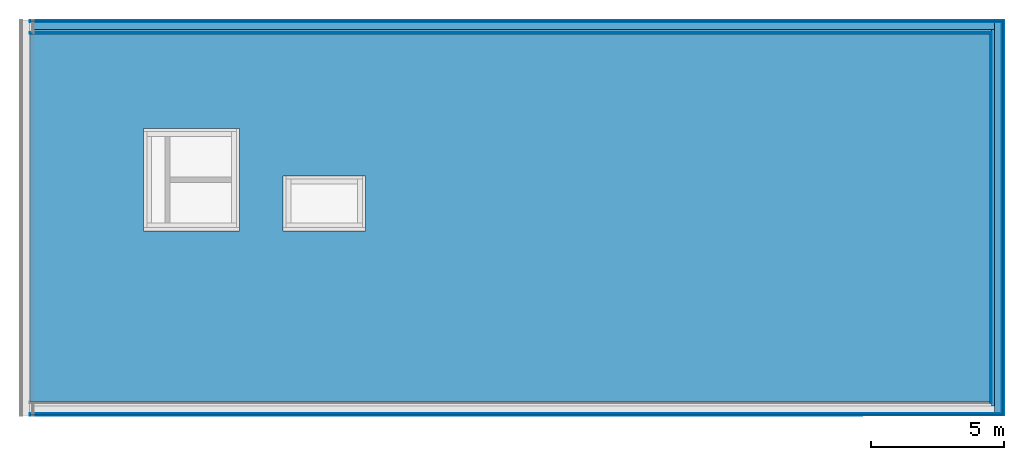
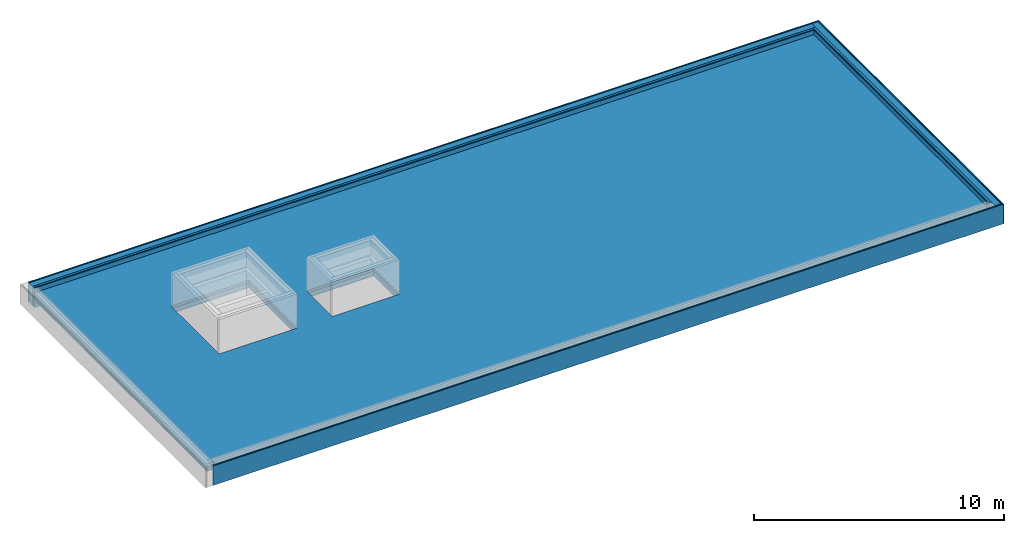
# One storey, part 2 of 3: 23 building element parts, 4 elements without a shape of their own.
"""IFC4 building model written with IfcOpenShell, lengths in metres."""

from ifc_helpers import new_model, entity, si_unit, converted_unit, derived_unit, direction, frame, origin_with_axes, place, context, subcontext, project, spatial, polygons, material, type_object, element, aggregate, save


model = new_model("IFC4")

# Units and contexts
model_context = context("Model", 3, precision=1e-05, world=origin_with_axes(), true_north=direction((0.0, 1.0)))
body_context = subcontext(model_context, "Body", "Model", "MODEL_VIEW")
ifc_project = project(units=[si_unit("LENGTHUNIT", "METRE"), si_unit("AREAUNIT", "SQUARE_METRE"), si_unit("VOLUMEUNIT", "CUBIC_METRE"), converted_unit("PLANEANGLEUNIT", "DEGREE", entity("IfcPlaneAngleMeasure", 0.0174532925199433), si_unit("PLANEANGLEUNIT", "RADIAN"), dimensions=[0, 0, 0, 0, 0, 0, 0]), converted_unit("TIMEUNIT", "Year", entity("IfcTimeMeasure", 31557600.0), si_unit("TIMEUNIT", "SECOND"), dimensions=[0, 0, 1, 0, 0, 0, 0]), si_unit("MASSUNIT", "GRAM", prefix="KILO"), si_unit("THERMODYNAMICTEMPERATUREUNIT", "DEGREE_CELSIUS"), si_unit("LUMINOUSINTENSITYUNIT", "LUMEN"), si_unit("ENERGYUNIT", "JOULE", prefix="MEGA"), derived_unit("THERMALCONDUCTANCEUNIT", [(si_unit("POWERUNIT", "WATT"), 1), (si_unit("LENGTHUNIT", "METRE"), -1), (si_unit("THERMODYNAMICTEMPERATUREUNIT", "KELVIN"), -1)]), derived_unit("SPECIFICHEATCAPACITYUNIT", [(si_unit("ENERGYUNIT", "JOULE"), 1), (si_unit("MASSUNIT", "GRAM", prefix="KILO"), -1), (si_unit("THERMODYNAMICTEMPERATUREUNIT", "KELVIN"), -1)]), derived_unit("MASSDENSITYUNIT", [(si_unit("MASSUNIT", "GRAM", prefix="KILO"), 1), (si_unit("VOLUMEUNIT", "CUBIC_METRE"), -1)])], contexts=[model_context])

# Site, building, storey
site_placement = place(None, origin_with_axes())
site = spatial("IfcSite", under=ifc_project, at=site_placement, CompositionType="ELEMENT")
building_placement = place(site_placement, origin_with_axes())
building = spatial("IfcBuilding", under=site, at=building_placement, CompositionType="ELEMENT")
storey_placement = place(building_placement, frame((0.0, 0.0, 13.5), z_axis=(0.0, 0.0, 1.0), x_axis=(1.0, 0.0, 0.0)))
storey = spatial("IfcBuildingStorey", under=building, at=storey_placement, Name="Dach", CompositionType="ELEMENT", Elevation=13.5)

# Wall, building element parts
wall_type = type_object("IfcWallType", Name="04a-00 520", PredefinedType="NOTDEFINED")
wall_1_placement = place(storey_placement, frame((60.446, 0.0, 0.0), z_axis=(0.0, 0.0, 1.0), x_axis=(0.0, 1.0, 0.0)))
wall_1 = element("IfcWall", 1, at=wall_1_placement, inside=storey, type_object=wall_type, PredefinedType="NOTDEFINED")
ifc_material_1 = material(Name="mit")
building_element_part_1_placement = place(wall_1_placement, origin_with_axes())
building_element_part_1 = element("IfcBuildingElementPart", 2, at=building_element_part_1_placement, material=ifc_material_1, Name="mit", PredefinedType="NOTDEFINED", context=body_context, shape_type="Tessellation", body=[
    polygons([(14.3309998908579, 0.515000000000001, 0.0), (0.515, 0.515000000000001, 0.0), (0.515, 0.520000000000003, 0.0), (14.3309998908572, 0.520000000000003, 0.0), (14.3309998908579, 0.515000000000001, 0.950000000000003), (0.515, 0.515000000000001, 0.950000000000003), (0.515, 0.520000000000003, 0.950000000000003), (14.3309998908572, 0.520000000000003, 0.950000000000003)], [[[1, 2, 3, 4]], [[5, 6, 2, 1]], [[3, 2, 6, 7]], [[4, 3, 7, 8]], [[4, 8, 5, 1]], [[8, 7, 6, 5]]], closed=True),
])
ifc_material_2 = material(Name="din_18948")
building_element_part_2_placement = place(wall_1_placement, origin_with_axes())
building_element_part_2 = element("IfcBuildingElementPart", 3, at=building_element_part_2_placement, material=ifc_material_2, Name="din_18948", PredefinedType="NOTDEFINED", context=body_context, shape_type="Tessellation", body=[
    polygons([(14.3529998908613, 0.493000000000002, 0.0), (0.493, 0.493000000000002, 0.0), (0.493, 0.515000000000001, 0.0), (14.3529998908579, 0.515000000000001, 0.0), (14.3529998908613, 0.493000000000002, 0.950000000000003), (0.493, 0.493000000000002, 0.950000000000003), (0.493, 0.515000000000001, 0.950000000000003), (14.3529998908579, 0.515000000000001, 0.950000000000003)], [[[1, 2, 3, 4]], [[5, 6, 2, 1]], [[3, 2, 6, 7]], [[4, 3, 7, 8]], [[4, 8, 5, 1]], [[8, 7, 6, 5]]], closed=True),
])
ifc_material_3 = material(Name="holz_fichte")
building_element_part_3_placement = place(wall_1_placement, origin_with_axes())
building_element_part_3 = element("IfcBuildingElementPart", 4, at=building_element_part_3_placement, material=ifc_material_3, Name="holz_fichte", PredefinedType="NOTDEFINED", context=body_context, shape_type="Tessellation", body=[
    polygons([(14.3829998908657, 0.463000000000001, 0.0), (0.463, 0.463000000000001, 0.0), (0.463, 0.493000000000002, 0.0), (14.3829998908612, 0.493000000000002, 0.0), (14.3829998908657, 0.463000000000001, 0.950000000000003), (0.463, 0.463000000000001, 0.950000000000003), (0.463, 0.493000000000002, 0.950000000000003), (14.3829998908612, 0.493000000000002, 0.950000000000003)], [[[1, 2, 3, 4]], [[5, 6, 2, 1]], [[3, 2, 6, 7]], [[4, 3, 7, 8]], [[4, 8, 5, 1]], [[8, 7, 6, 5]]], closed=True),
])
ifc_material_4 = material(Name="5")
building_element_part_4_placement = place(wall_1_placement, origin_with_axes())
building_element_part_4 = element("IfcBuildingElementPart", 5, at=building_element_part_4_placement, material=ifc_material_4, Name="5", PredefinedType="NOTDEFINED", context=body_context, shape_type="Tessellation", body=[
    polygons([(14.4829998908807, 0.362999999999999, 0.0), (0.363, 0.362999999999999, 0.0), (0.363, 0.463000000000001, 0.0), (14.4829998908657, 0.463000000000001, 0.0), (14.4829998908807, 0.362999999999999, 0.950000000000003), (0.363, 0.362999999999999, 0.950000000000003), (0.363, 0.463000000000001, 0.950000000000003), (14.4829998908657, 0.463000000000001, 0.950000000000003)], [[[1, 2, 3, 4]], [[5, 6, 2, 1]], [[3, 2, 6, 7]], [[4, 3, 7, 8]], [[4, 8, 5, 1]], [[8, 7, 6, 5]]], closed=True),
])
ifc_material_5 = material()
building_element_part_5_placement = place(wall_1_placement, origin_with_axes())
building_element_part_5 = element("IfcBuildingElementPart", 6, at=building_element_part_5_placement, material=ifc_material_5, PredefinedType="NOTDEFINED", context=body_context, shape_type="Tessellation", body=[
    polygons([(14.7629998909227, 0.0829999999999984, 0.0), (0.083, 0.0829999999999984, 0.0), (0.083, 0.362999999999999, 0.0), (14.7629998908807, 0.362999999999999, 0.0), (14.7629998909227, 0.0829999999999984, 0.950000000000003), (0.083, 0.0829999999999984, 0.950000000000003), (0.083, 0.362999999999999, 0.950000000000003), (14.7629998908807, 0.362999999999999, 0.950000000000003)], [[[1, 2, 3, 4]], [[5, 6, 2, 1]], [[3, 2, 6, 7]], [[4, 3, 7, 8]], [[4, 8, 5, 1]], [[8, 7, 6, 5]]], closed=True),
])
building_element_part_6_placement = place(wall_1_placement, origin_with_axes())
building_element_part_6 = element("IfcBuildingElementPart", 7, at=building_element_part_6_placement, material=ifc_material_3, Name="holz_fichte", PredefinedType="NOTDEFINED", context=body_context, shape_type="Tessellation", body=[
    polygons([(14.8269998909323, 0.0189999999999984, 0.0), (0.019, 0.0189999999999984, 0.0), (0.019, 0.0589999999999975, 0.0), (14.8269998909263, 0.0589999999999975, 0.0), (14.8269998909323, 0.0189999999999984, 0.950000000000003), (0.019, 0.0189999999999984, 0.950000000000003), (0.019, 0.0589999999999975, 0.950000000000003), (14.8269998909263, 0.0589999999999975, 0.950000000000003)], [[[1, 2, 3, 4]], [[5, 6, 2, 1]], [[3, 2, 6, 7]], [[4, 3, 7, 8]], [[4, 8, 5, 1]], [[8, 7, 6, 5]]], closed=True),
])
ifc_material_6 = material()
building_element_part_7_placement = place(wall_1_placement, origin_with_axes())
building_element_part_7 = element("IfcBuildingElementPart", 8, at=building_element_part_7_placement, material=ifc_material_6, PredefinedType="NOTDEFINED", context=body_context, shape_type="Tessellation", body=[
    polygons([(14.8459998909351, 0.0, 0.0), (0.0, 0.0, 0.0), (0.0, 0.0189999999999984, 0.0), (14.8459998909323, 0.0189999999999984, 0.0), (14.8459998909351, 0.0, 0.950000000000003), (0.0, 0.0, 0.950000000000003), (0.0, 0.0189999999999984, 0.950000000000003), (14.8459998909323, 0.0189999999999984, 0.950000000000003)], [[[1, 2, 3, 4]], [[5, 6, 2, 1]], [[3, 2, 6, 7]], [[4, 3, 7, 8]], [[4, 8, 5, 1]], [[8, 7, 6, 5]]], closed=True),
])

wall_2_placement = place(storey_placement, frame((60.446, 14.8459998909351, 0.0), z_axis=(0.0, 0.0, 1.0), x_axis=(-1.0, -1.49825140774897e-10, 0.0)))
wall_2 = element("IfcWall", 9, at=wall_2_placement, inside=storey, type_object=wall_type, PredefinedType="NOTDEFINED")
building_element_part_8_placement = place(wall_2_placement, origin_with_axes())
building_element_part_8 = element("IfcBuildingElementPart", 10, at=building_element_part_8_placement, material=ifc_material_2, Name="din_18948", PredefinedType="NOTDEFINED", context=body_context, shape_type="Tessellation", body=[
    polygons([(36.5580000000033, 0.51499999452269, 0.0), (36.558, 0.492999994522691, 0.0), (0.515000000073861, 0.492999999922841, 0.0), (0.515000000077158, 0.514999999922841, 0.0), (36.5580000000033, 0.514999994522691, 0.950000000000003), (36.558, 0.492999994522691, 0.950000000000003), (0.515000000073861, 0.492999999922841, 0.950000000000003), (0.515000000077158, 0.514999999922841, 0.950000000000003)], [[[1, 2, 3, 4]], [[1, 5, 6, 2]], [[2, 6, 7, 3]], [[4, 3, 7, 8]], [[5, 1, 4, 8]], [[6, 5, 8, 7]]], closed=True),
])
building_element_part_9_placement = place(wall_2_placement, origin_with_axes())
building_element_part_9 = element("IfcBuildingElementPart", 11, at=building_element_part_9_placement, material=ifc_material_3, Name="holz_fichte", PredefinedType="NOTDEFINED", context=body_context, shape_type="Tessellation", body=[
    polygons([(36.5580000000045, 0.492999994522691, 0.0), (36.558, 0.46299999452269, 0.0), (0.493000000069372, 0.462999999926136, 0.0), (0.493000000073863, 0.492999999926136, 0.0), (36.5580000000045, 0.492999994522691, 0.950000000000003), (36.558, 0.46299999452269, 0.950000000000003), (0.493000000069372, 0.462999999926136, 0.950000000000003), (0.493000000073863, 0.492999999926136, 0.950000000000003)], [[[1, 2, 3, 4]], [[1, 5, 6, 2]], [[2, 6, 7, 3]], [[4, 3, 7, 8]], [[5, 1, 4, 8]], [[6, 5, 8, 7]]], closed=True),
])
building_element_part_10_placement = place(wall_2_placement, origin_with_axes())
building_element_part_10 = element("IfcBuildingElementPart", 12, at=building_element_part_10_placement, material=ifc_material_4, Name="5", PredefinedType="NOTDEFINED", context=body_context, shape_type="Tessellation", body=[
    polygons([(36.558000000015, 0.46299999452269, 0.0), (36.558, 0.36299999452269, 0.0), (0.463000000054386, 0.362999999930631, 0.0), (0.463000000069371, 0.462999999930633, 0.0), (36.558000000015, 0.46299999452269, 0.950000000000003), (36.558, 0.36299999452269, 0.950000000000003), (0.463000000054386, 0.362999999930631, 0.950000000000003), (0.463000000069371, 0.462999999930633, 0.950000000000003)], [[[1, 2, 3, 4]], [[1, 5, 6, 2]], [[2, 6, 7, 3]], [[4, 3, 7, 8]], [[5, 1, 4, 8]], [[6, 5, 8, 7]]], closed=True),
])
building_element_part_11_placement = place(wall_2_placement, origin_with_axes())
building_element_part_11 = element("IfcBuildingElementPart", 13, at=building_element_part_11_placement, material=ifc_material_1, Name="mit", PredefinedType="NOTDEFINED", context=body_context, shape_type="Tessellation", body=[
    polygons([(36.5580000000008, 0.51999999452269, 0.0), (36.558, 0.51499999452269, 0.0), (0.520000000077161, 0.514999999922091, 0.0), (0.520000000077914, 0.51999999992209, 0.0), (36.5580000000008, 0.51999999452269, 0.950000000000003), (36.558, 0.514999994522691, 0.950000000000003), (0.520000000077161, 0.514999999922091, 0.950000000000003), (0.520000000077914, 0.51999999992209, 0.950000000000003)], [[[1, 2, 3, 4]], [[1, 5, 6, 2]], [[2, 6, 7, 3]], [[4, 3, 7, 8]], [[5, 1, 4, 8]], [[6, 5, 8, 7]]], closed=True),
])
ifc_material_7 = material(Name="fichte")
building_element_part_12_placement = place(wall_2_placement, origin_with_axes())
building_element_part_12 = element("IfcBuildingElementPart", 14, at=building_element_part_12_placement, material=ifc_material_7, Name="fichte", PredefinedType="NOTDEFINED", context=body_context, shape_type="Tessellation", body=[
    polygons([(36.5580000000036, 0.0829999945226909, 0.0), (36.558, 0.05899999452269, 0.0), (0.0830000000088376, 0.058999999987563, 0.0), (0.0830000000124329, 0.0829999999875639, 0.0), (36.5580000000036, 0.0829999945226909, 0.950000000000003), (36.558, 0.05899999452269, 0.950000000000003), (0.0830000000088376, 0.058999999987563, 0.950000000000003), (0.0830000000124329, 0.0829999999875639, 0.950000000000003)], [[[1, 2, 3, 4]], [[1, 5, 6, 2]], [[2, 6, 7, 3]], [[4, 3, 7, 8]], [[5, 1, 4, 8]], [[6, 5, 8, 7]]], closed=True),
])
building_element_part_13_placement = place(wall_2_placement, origin_with_axes())
building_element_part_13 = element("IfcBuildingElementPart", 15, at=building_element_part_13_placement, material=ifc_material_3, Name="holz_fichte", PredefinedType="NOTDEFINED", context=body_context, shape_type="Tessellation", body=[
    polygons([(36.558000000006, 0.05899999452269, 0.0), (36.558, 0.0189999945226909, 0.0), (0.0590000000028468, 0.018999999991161, 0.0), (0.0590000000088367, 0.0589999999911601, 0.0), (36.558000000006, 0.05899999452269, 0.950000000000003), (36.558, 0.0189999945226909, 0.950000000000003), (0.0590000000028468, 0.018999999991161, 0.950000000000003), (0.0590000000088367, 0.0589999999911601, 0.950000000000003)], [[[1, 2, 3, 4]], [[1, 5, 6, 2]], [[2, 6, 7, 3]], [[4, 3, 7, 8]], [[5, 1, 4, 8]], [[6, 5, 8, 7]]], closed=True),
])
building_element_part_14_placement = place(wall_2_placement, origin_with_axes())
building_element_part_14 = element("IfcBuildingElementPart", 16, at=building_element_part_14_placement, material=ifc_material_5, PredefinedType="NOTDEFINED", context=body_context, shape_type="Tessellation", body=[
    polygons([(36.558000000042, 0.36299999452269, 0.0), (36.558, 0.0829999945226909, 0.0), (0.363000000012434, 0.0829999999456135, 0.0), (0.363000000054384, 0.362999999945613, 0.0), (36.558000000042, 0.36299999452269, 0.950000000000003), (36.558, 0.0829999945226909, 0.950000000000003), (0.363000000012434, 0.0829999999456135, 0.950000000000003), (0.363000000054384, 0.362999999945613, 0.950000000000003)], [[[1, 2, 3, 4]], [[1, 5, 6, 2]], [[2, 6, 7, 3]], [[4, 3, 7, 8]], [[5, 1, 4, 8]], [[6, 5, 8, 7]]], closed=True),
])
building_element_part_15_placement = place(wall_2_placement, origin_with_axes())
building_element_part_15 = element("IfcBuildingElementPart", 17, at=building_element_part_15_placement, material=ifc_material_6, PredefinedType="NOTDEFINED", context=body_context, shape_type="Tessellation", body=[
    polygons([(36.5580000000028, 0.0189999945226909, 0.0), (36.558, -5.47730927280554e-09, 0.0), (0.0189999999999984, 0.0, 0.0), (0.0190000000028476, 0.0189999999971526, 0.0), (36.5580000000028, 0.0189999945226909, 0.950000000000003), (36.558, -5.47730927280554e-09, 0.950000000000003), (0.0189999999999984, 0.0, 0.950000000000003), (0.0190000000028476, 0.0189999999971526, 0.950000000000003)], [[[1, 2, 3, 4]], [[1, 5, 6, 2]], [[2, 6, 7, 3]], [[4, 3, 7, 8]], [[5, 1, 4, 8]], [[6, 5, 8, 7]]], closed=True),
])
aggregate(wall_2, [building_element_part_8, building_element_part_9, building_element_part_10, building_element_part_11, building_element_part_12, building_element_part_13, building_element_part_14, building_element_part_15])

# Building element part
building_element_part_16_placement = place(wall_1_placement, origin_with_axes())
building_element_part_16 = element("IfcBuildingElementPart", 18, at=building_element_part_16_placement, material=ifc_material_7, Name="fichte", PredefinedType="NOTDEFINED", context=body_context, shape_type="Tessellation", body=[
    polygons([(14.7869998909263, 0.0589999999999975, 0.0), (0.059, 0.0589999999999975, 0.0), (0.059, 0.0829999999999984, 0.0), (14.7869998909227, 0.0829999999999984, 0.0), (14.7869998909263, 0.0589999999999975, 0.950000000000003), (0.059, 0.0589999999999975, 0.950000000000003), (0.059, 0.0829999999999984, 0.950000000000003), (14.7869998909227, 0.0829999999999984, 0.950000000000003)], [[[1, 2, 3, 4]], [[5, 6, 2, 1]], [[3, 2, 6, 7]], [[4, 3, 7, 8]], [[4, 8, 5, 1]], [[8, 7, 6, 5]]], closed=True),
])

aggregate(wall_1, [building_element_part_1, building_element_part_2, building_element_part_3, building_element_part_4, building_element_part_5, building_element_part_6, building_element_part_7, building_element_part_16])

# Covering, building element parts
covering_type = type_object("IfcCoveringType", Name="Kies 360", PredefinedType="ROOFING")
covering_placement = place(storey_placement, frame((23.888, 0.52, 0.73), z_axis=(0.0, 0.0, 1.0), x_axis=(1.0, 0.0, 0.0)))
covering = element("IfcCovering", 19, at=covering_placement, inside=storey, type_object=covering_type, Name="Decke-001", PredefinedType="ROOFING")
ifc_material_8 = material(Name="Kies")
building_element_part_17_placement = place(covering_placement, origin_with_axes())
building_element_part_17 = element("IfcBuildingElementPart", 20, at=building_element_part_17_placement, material=ifc_material_8, Name="Kies", PredefinedType="NOTDEFINED", context=body_context, shape_type="Tessellation", body=[
    polygons([(36.038, 0.0, -0.119999999999999), (36.038, 0.0, 0.0), (0.0, 0.0, 0.0), (0.0, 0.0, -0.119999999999999), (36.038, 13.8059998825556, -0.119999999999999), (36.038, 13.8059998825556, 0.0), (0.0, 13.8059998825556, 0.0), (4.27000000000001, 10.2549999454676, 0.0), (7.87000000000002, 10.2549999454676, 0.0), (7.87000000000002, 6.41499994546755, 0.0), (4.27000000000001, 6.41499994546755, 0.0), (9.49700000000001, 8.47299994546756, 0.0), (12.605, 8.47299994546756, 0.0), (12.605, 6.41499994546755, 0.0), (9.49700000000001, 6.41499994546755, 0.0), (0.0, 13.8059998825556, -0.119999999999999), (4.27000000000001, 10.2549999454676, -0.119999999999999), (4.27000000000001, 6.41499994546755, -0.119999999999999), (7.87000000000002, 6.41499994546755, -0.119999999999999), (7.87000000000002, 10.2549999454676, -0.119999999999999), (9.49700000000001, 8.47299994546756, -0.119999999999999), (9.49700000000001, 6.41499994546755, -0.119999999999999), (12.605, 6.41499994546755, -0.119999999999999), (12.605, 8.47299994546756, -0.119999999999999)], [[[1, 2, 3, 4]], [[5, 6, 2, 1]], [[3, 2, 6, 7], [8, 9, 10, 11], [12, 13, 14, 15]], [[4, 3, 7, 16]], [[4, 16, 5, 1], [17, 18, 19, 20], [21, 22, 23, 24]], [[16, 7, 6, 5]], [[20, 9, 8, 17]], [[19, 10, 9, 20]], [[18, 11, 10, 19]], [[17, 8, 11, 18]], [[24, 13, 12, 21]], [[23, 14, 13, 24]], [[22, 15, 14, 23]], [[21, 12, 15, 22]]], closed=True),
])
ifc_material_9 = material(Name="XPS")
building_element_part_18_placement = place(covering_placement, origin_with_axes())
building_element_part_18 = element("IfcBuildingElementPart", 21, at=building_element_part_18_placement, material=ifc_material_9, Name="XPS", PredefinedType="NOTDEFINED", context=body_context, shape_type="Tessellation", body=[
    polygons([(36.038, 0.0, -0.345000000000001), (36.038, 0.0, -0.125), (0.0, 0.0, -0.125), (0.0, 0.0, -0.345000000000001), (36.038, 13.8059998825556, -0.345000000000001), (36.038, 13.8059998825556, -0.125), (0.0, 13.8059998825556, -0.125), (4.27000000000001, 10.2549999454676, -0.125), (7.87000000000002, 10.2549999454676, -0.125), (7.87000000000002, 6.41499994546755, -0.125), (4.27000000000001, 6.41499994546755, -0.125), (9.49700000000001, 8.47299994546756, -0.125), (12.605, 8.47299994546756, -0.125), (12.605, 6.41499994546755, -0.125), (9.49700000000001, 6.41499994546755, -0.125), (0.0, 13.8059998825556, -0.345000000000001), (4.27000000000001, 10.2549999454676, -0.345000000000001), (4.27000000000001, 6.41499994546755, -0.345000000000001), (7.87000000000002, 6.41499994546755, -0.345000000000001), (7.87000000000002, 10.2549999454676, -0.345000000000001), (9.49700000000001, 8.47299994546756, -0.345000000000001), (9.49700000000001, 6.41499994546755, -0.345000000000001), (12.605, 6.41499994546755, -0.345000000000001), (12.605, 8.47299994546756, -0.345000000000001)], [[[1, 2, 3, 4]], [[5, 6, 2, 1]], [[3, 2, 6, 7], [8, 9, 10, 11], [12, 13, 14, 15]], [[4, 3, 7, 16]], [[4, 16, 5, 1], [17, 18, 19, 20], [21, 22, 23, 24]], [[16, 7, 6, 5]], [[20, 9, 8, 17]], [[19, 10, 9, 20]], [[18, 11, 10, 19]], [[17, 8, 11, 18]], [[24, 13, 12, 21]], [[23, 14, 13, 24]], [[22, 15, 14, 23]], [[21, 12, 15, 22]]], closed=True),
])
ifc_material_10 = material(Name="Folie")
building_element_part_19_placement = place(covering_placement, origin_with_axes())
building_element_part_19 = element("IfcBuildingElementPart", 22, at=building_element_part_19_placement, material=ifc_material_10, Name="Folie", PredefinedType="NOTDEFINED", context=body_context, shape_type="Tessellation", body=[
    polygons([(36.038, 0.0, -0.125), (36.038, 0.0, -0.119999999999999), (0.0, 0.0, -0.119999999999999), (0.0, 0.0, -0.125), (36.038, 13.8059998825556, -0.125), (36.038, 13.8059998825556, -0.119999999999999), (0.0, 13.8059998825556, -0.119999999999999), (4.27000000000001, 10.2549999454676, -0.119999999999999), (7.87000000000002, 10.2549999454676, -0.119999999999999), (7.87000000000002, 6.41499994546755, -0.119999999999999), (4.27000000000001, 6.41499994546755, -0.119999999999999), (9.49700000000001, 8.47299994546756, -0.119999999999999), (12.605, 8.47299994546756, -0.119999999999999), (12.605, 6.41499994546755, -0.119999999999999), (9.49700000000001, 6.41499994546755, -0.119999999999999), (0.0, 13.8059998825556, -0.125), (4.27000000000001, 10.2549999454676, -0.125), (4.27000000000001, 6.41499994546755, -0.125), (7.87000000000002, 6.41499994546755, -0.125), (7.87000000000002, 10.2549999454676, -0.125), (9.49700000000001, 8.47299994546756, -0.125), (9.49700000000001, 6.41499994546755, -0.125), (12.605, 6.41499994546755, -0.125), (12.605, 8.47299994546756, -0.125)], [[[1, 2, 3, 4]], [[5, 6, 2, 1]], [[3, 2, 6, 7], [8, 9, 10, 11], [12, 13, 14, 15]], [[4, 3, 7, 16]], [[4, 16, 5, 1], [17, 18, 19, 20], [21, 22, 23, 24]], [[16, 7, 6, 5]], [[20, 9, 8, 17]], [[19, 10, 9, 20]], [[18, 11, 10, 19]], [[17, 8, 11, 18]], [[24, 13, 12, 21]], [[23, 14, 13, 24]], [[22, 15, 14, 23]], [[21, 12, 15, 22]]], closed=True),
])
building_element_part_20_placement = place(covering_placement, origin_with_axes())
building_element_part_20 = element("IfcBuildingElementPart", 23, at=building_element_part_20_placement, material=ifc_material_10, Name="Folie", PredefinedType="NOTDEFINED", context=body_context, shape_type="Tessellation", body=[
    polygons([(0.0, 0.0, -0.359999999999999), (36.038, 0.0, -0.359999999999999), (36.038, 0.0, -0.345000000000001), (0.0, 0.0, -0.345000000000001), (0.0, 13.8059998825556, -0.359999999999999), (36.038, 13.8059998825556, -0.359999999999999), (4.27000000000001, 10.2549999454676, -0.359999999999999), (4.27000000000001, 6.41499994546755, -0.359999999999999), (7.87000000000002, 6.41499994546755, -0.359999999999999), (7.87000000000002, 10.2549999454676, -0.359999999999999), (9.49700000000001, 8.47299994546756, -0.359999999999999), (9.49700000000001, 6.41499994546755, -0.359999999999999), (12.605, 6.41499994546755, -0.359999999999999), (12.605, 8.47299994546756, -0.359999999999999), (36.038, 13.8059998825556, -0.345000000000001), (0.0, 13.8059998825556, -0.345000000000001), (4.27000000000001, 10.2549999454676, -0.345000000000001), (7.87000000000002, 10.2549999454676, -0.345000000000001), (7.87000000000002, 6.41499994546755, -0.345000000000001), (4.27000000000001, 6.41499994546755, -0.345000000000001), (9.49700000000001, 8.47299994546756, -0.345000000000001), (12.605, 8.47299994546756, -0.345000000000001), (12.605, 6.41499994546755, -0.345000000000001), (9.49700000000001, 6.41499994546755, -0.345000000000001)], [[[1, 2, 3, 4]], [[1, 5, 6, 2], [7, 8, 9, 10], [11, 12, 13, 14]], [[2, 6, 15, 3]], [[4, 3, 15, 16], [17, 18, 19, 20], [21, 22, 23, 24]], [[5, 1, 4, 16]], [[6, 5, 16, 15]], [[8, 7, 17, 20]], [[9, 8, 20, 19]], [[10, 9, 19, 18]], [[7, 10, 18, 17]], [[12, 11, 21, 24]], [[13, 12, 24, 23]], [[14, 13, 23, 22]], [[11, 14, 22, 21]]], closed=True),
])
aggregate(covering, [building_element_part_17, building_element_part_18, building_element_part_19, building_element_part_20])

# Wall, building element parts
wall_3_placement = place(storey_placement, frame((23.888, 0.0, 0.0), z_axis=(0.0, 0.0, 1.0), x_axis=(1.0, 0.0, 0.0)))
wall_3 = element("IfcWall", 24, at=wall_3_placement, inside=storey, type_object=wall_type, PredefinedType="NOTDEFINED")
building_element_part_21_placement = place(wall_3_placement, origin_with_axes())
building_element_part_21 = element("IfcBuildingElementPart", 25, at=building_element_part_21_placement, material=ifc_material_7, Name="fichte", PredefinedType="NOTDEFINED", context=body_context, shape_type="Tessellation", body=[
    polygons([(36.475, 0.0590000000000022, 0.0), (0.0, 0.059, 0.0), (0.0, 0.083, 0.0), (36.475, 0.0830000000000023, 0.0), (36.475, 0.0590000000000023, 0.950000000000003), (0.0, 0.0590000000000001, 0.950000000000003), (0.0, 0.0830000000000001, 0.950000000000003), (36.475, 0.0830000000000023, 0.950000000000003)], [[[1, 2, 3, 4]], [[5, 6, 2, 1]], [[3, 2, 6, 7]], [[4, 3, 7, 8]], [[4, 8, 5, 1]], [[8, 7, 6, 5]]], closed=True),
])
building_element_part_22_placement = place(wall_3_placement, origin_with_axes())
building_element_part_22 = element("IfcBuildingElementPart", 26, at=building_element_part_22_placement, material=ifc_material_6, PredefinedType="NOTDEFINED", context=body_context, shape_type="Tessellation", body=[
    polygons([(36.539, 0.0, 0.0), (0.0, 0.0, 0.0), (0.0, 0.019, 0.0), (36.539, 0.0190000000000022, 0.0), (36.539, 0.0, 0.950000000000003), (0.0, 0.0, 0.950000000000003), (0.0, 0.0190000000000001, 0.950000000000003), (36.539, 0.0190000000000023, 0.950000000000003)], [[[1, 2, 3, 4]], [[5, 6, 2, 1]], [[3, 2, 6, 7]], [[4, 3, 7, 8]], [[4, 8, 5, 1]], [[8, 7, 6, 5]]], closed=True),
])
building_element_part_23_placement = place(wall_3_placement, origin_with_axes())
building_element_part_23 = element("IfcBuildingElementPart", 27, at=building_element_part_23_placement, material=ifc_material_3, Name="holz_fichte", PredefinedType="NOTDEFINED", context=body_context, shape_type="Tessellation", body=[
    polygons([(36.499, 0.0190000000000022, 0.0), (0.0, 0.019, 0.0), (0.0, 0.059, 0.0), (36.499, 0.0590000000000022, 0.0), (36.499, 0.0190000000000023, 0.950000000000003), (0.0, 0.0190000000000001, 0.950000000000003), (0.0, 0.0590000000000001, 0.950000000000003), (36.499, 0.0590000000000023, 0.950000000000003)], [[[1, 2, 3, 4]], [[5, 6, 2, 1]], [[3, 2, 6, 7]], [[4, 3, 7, 8]], [[4, 8, 5, 1]], [[8, 7, 6, 5]]], closed=True),
])
aggregate(wall_3, [building_element_part_21, building_element_part_22, building_element_part_23])

save(model, "model.ifc")
